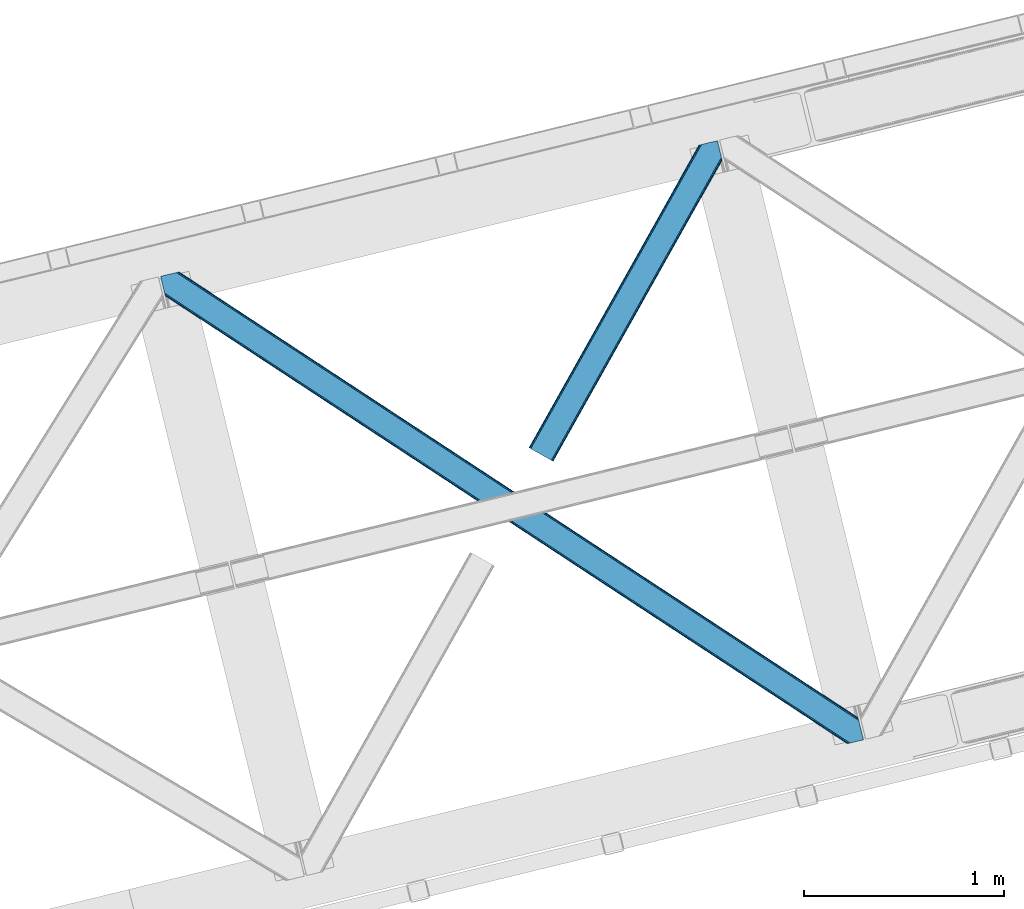
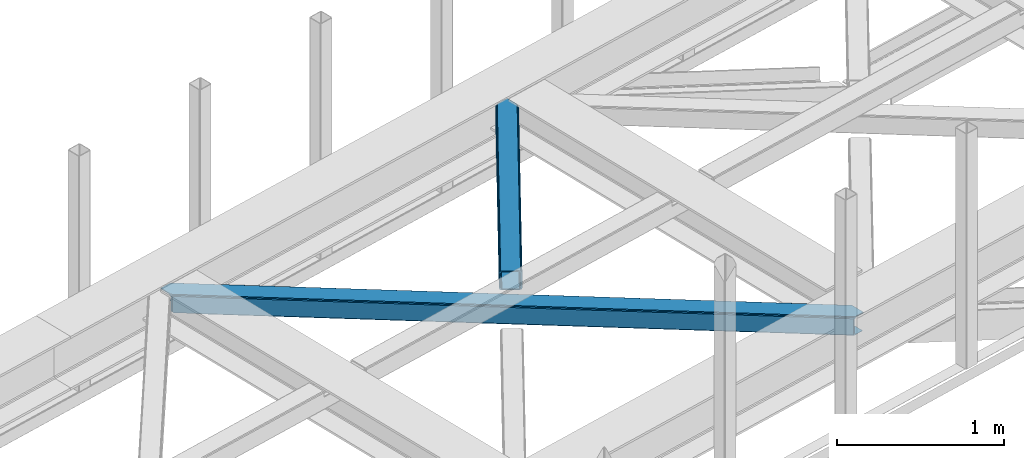
# One storey, part 54 of 67: 2 members.
"""IFC4 building model written with IfcOpenShell, lengths in millimetres."""

from ifc_helpers import new_model, entity, si_unit, converted_unit, derived_unit, direction, frame, origin, place, context, subcontext, project, spatial, triangles, type_object, element, save


model = new_model("IFC4")

# Units and contexts
model_context = context("Model", 3, precision=0.01, world=origin(), true_north=direction((6.12303176911189e-17, 1.0)))
plan_context = context("Plan", 3, precision=0.01, world=origin(), true_north=direction((6.12303176911189e-17, 1.0)))
body_context = subcontext(model_context, "Body", "Model", "MODEL_VIEW")
ifc_project = project(units=[si_unit("LENGTHUNIT", "METRE", prefix="MILLI"), si_unit("AREAUNIT", "SQUARE_METRE"), si_unit("VOLUMEUNIT", "CUBIC_METRE"), converted_unit("PLANEANGLEUNIT", "DEGREE", entity("IfcRatioMeasure", 0.0174532925199433), si_unit("PLANEANGLEUNIT", "RADIAN"), dimensions=[0, 0, 0, 0, 0, 0, 0]), si_unit("MASSUNIT", "GRAM", prefix="KILO"), derived_unit("MASSDENSITYUNIT", [(si_unit("MASSUNIT", "GRAM", prefix="KILO"), 1), (si_unit("LENGTHUNIT", "METRE"), -3)]), derived_unit("MOMENTOFINERTIAUNIT", [(si_unit("LENGTHUNIT", "METRE"), 4)]), si_unit("TIMEUNIT", "SECOND"), si_unit("FREQUENCYUNIT", "HERTZ"), si_unit("THERMODYNAMICTEMPERATUREUNIT", "DEGREE_CELSIUS"), derived_unit("THERMALTRANSMITTANCEUNIT", [(si_unit("MASSUNIT", "GRAM", prefix="KILO"), 1), (si_unit("THERMODYNAMICTEMPERATUREUNIT", "KELVIN"), -1), (si_unit("TIMEUNIT", "SECOND"), -3)]), derived_unit("VOLUMETRICFLOWRATEUNIT", [(si_unit("LENGTHUNIT", "METRE"), 3), (si_unit("TIMEUNIT", "SECOND"), -1)]), derived_unit("MASSFLOWRATEUNIT", [(si_unit("MASSUNIT", "GRAM", prefix="KILO"), 1), (si_unit("TIMEUNIT", "SECOND"), -1)]), derived_unit("ROTATIONALFREQUENCYUNIT", [(si_unit("TIMEUNIT", "SECOND"), -1)]), si_unit("ELECTRICCURRENTUNIT", "AMPERE"), si_unit("ELECTRICVOLTAGEUNIT", "VOLT"), si_unit("POWERUNIT", "WATT"), si_unit("FORCEUNIT", "NEWTON", prefix="KILO"), si_unit("ILLUMINANCEUNIT", "LUX"), si_unit("LUMINOUSFLUXUNIT", "LUMEN"), si_unit("LUMINOUSINTENSITYUNIT", "CANDELA"), derived_unit("USERDEFINED", [(si_unit("MASSUNIT", "GRAM", prefix="KILO"), -1), (si_unit("LENGTHUNIT", "METRE"), -2), (si_unit("TIMEUNIT", "SECOND"), 3), (si_unit("LUMINOUSFLUXUNIT", "LUMEN"), 1)]), derived_unit("LINEARVELOCITYUNIT", [(si_unit("LENGTHUNIT", "METRE"), 1), (si_unit("TIMEUNIT", "SECOND"), -1)]), si_unit("PRESSUREUNIT", "PASCAL"), derived_unit("USERDEFINED", [(si_unit("LENGTHUNIT", "METRE"), -2), (si_unit("MASSUNIT", "GRAM", prefix="KILO"), 1), (si_unit("TIMEUNIT", "SECOND"), -2)]), derived_unit("LINEARFORCEUNIT", [(si_unit("MASSUNIT", "GRAM", prefix="KILO"), 1), (si_unit("LENGTHUNIT", "METRE"), 1), (si_unit("TIMEUNIT", "SECOND"), -2), (si_unit("LENGTHUNIT", "METRE"), -1)]), derived_unit("PLANARFORCEUNIT", [(si_unit("MASSUNIT", "GRAM", prefix="KILO"), 1), (si_unit("LENGTHUNIT", "METRE"), 1), (si_unit("TIMEUNIT", "SECOND"), -2), (si_unit("LENGTHUNIT", "METRE"), -2)])], contexts=[model_context, plan_context])

# Site, building, storey
site_placement = place(None, origin())
site = spatial("IfcSite", under=ifc_project, at=site_placement, CompositionType="ELEMENT")
building_placement = place(site_placement, origin())
building = spatial("IfcBuilding", under=site, at=building_placement, CompositionType="ELEMENT")
storey_placement = place(building_placement, frame((0.0, 0.0, 19800.0)))
storey = spatial("IfcBuildingStorey", under=building, at=storey_placement, CompositionType="ELEMENT", Elevation=19800.0)

# Members
member_type_1 = type_object("IfcMemberType", PredefinedType="BRACE")
member_1_placement = place(storey_placement, frame((-11734.9697570801, 15585.6370422363, 3822.99993896484)))
element("IfcMember", 1, at=member_1_placement, inside=storey, type_object=member_type_1, ObjectType="Steel Horizontal Brace", PredefinedType="BRACE", context=body_context, shape_type="Tessellation", body=[
    triangles([(2937.7294052124, 494.760498046875, 17.5012573242202), (3489.95093078613, 132.252392578124, 122.499499511719), (3489.95093078613, 132.252392578124, 17.5012573242202), (2364.46672210693, 871.079388427734, 17.5012573242202), (1791.19996948242, 1247.39827880859, 17.5012573242202), (93.3036071777333, 2361.98373413086, 122.499499511719), (644.675765991211, 2000.03838500976, 17.5012573242202), (93.3036071777333, 2361.98373413086, 17.5012573242202), (1217.93728637695, 1623.71833190918, 17.5012573242202), (3496.02555999756, 107.331820678712, 140.00075683594), (3493.70128326416, 116.868447875977, 138.668280029298), (70.0515380859379, 2356.31547546387, 140.00075683594), (78.9486694335938, 2358.48394775391, 138.668280029298), (3491.73047332764, 124.954000854492, 134.87548828125), (86.4947204589844, 2360.32337036133, 134.87548828125), (3490.41311187744, 130.355996704102, 129.196765136719), (91.5327850341801, 2361.5523651123, 129.196765136719), (18.1488922119133, 2264.78617858887, 140.00075683594), (0.0, 2339.23977355957, 140.00075683594), (3459.55685577393, 5.66825866699219, 140.00075683594), (3517.37193145752, 19.761584472657, 140.00075683594), (3436.30420532227, 0.0, 122.499499511719), (3438.07560882568, 0.431369018555415, 129.196765136719), (24.2241027832024, 2239.86444396973, 122.499499511719), (23.7613403320302, 2241.76083984375, 129.196765136719), (3443.11367340088, 1.66036376953161, 134.87548828125), (22.4439788818363, 2247.16399841309, 134.87548828125), (3450.65972442627, 3.49978637695313, 138.668280029298), (20.4731689453129, 2255.24838867188, 138.668280029298), (1732.10008850098, 1118.72590026855, 17.5012573242202), (2308.23352661133, 740.523403930663, 17.5012573242202), (2884.36754608154, 362.320907592773, 17.5012573242202), (3436.30420532227, 0.0, 17.5012573242202), (1155.9701385498, 1496.92839660645, 17.5012573242202), (579.836700439453, 1875.13089294434, 17.5012573242202), (24.2241027832024, 2239.86444396973, 17.5012573242202), (21.3312561035145, 2251.7299987793, 122.197192382813), (20.0138946533207, 2257.13199462891, 127.873590087893), (21.7940185546868, 2249.83244018555, 115.499926757813), (21.7940185546868, 2249.83244018555, 24.5008300781265), (21.2382385253895, 2252.11137084961, 17.8686767578147), (21.1254547119133, 2252.57413330078, 16.5199218750022), (24.2136383056641, 2239.90397644043, 16.5199218750022), (18.0430847167972, 2265.21754760742, 131.668707275392), (15.7188079833977, 2274.75417480469, 133.001184082033), (0.0, 2339.23977355957, 133.001184082033), (3468.86035766602, 7.93556213378906, 133.001184082033), (3459.96322631836, 5.76708984375, 131.668707275392), (3452.41775665283, 3.92766723632849, 127.873590087893), (3447.37504119873, 2.69867248535229, 122.197192382813), (3445.60828857422, 2.26846618652417, 115.499926757813), (2899.81544036865, 360.552410888671, 24.5008300781265), (3445.60828857422, 2.26846618652417, 24.5008300781265), (2319.7380569458, 741.344284057617, 24.5008300781265), (1739.66009216309, 1122.13499450684, 24.5008300781265), (579.508813476563, 1883.71874084473, 24.5008300781265), (1159.58735961914, 1502.92803039551, 24.5008300781265), (60.7474548339833, 2354.04817199707, 133.001184082033), (3498.45564422607, 97.3626617431637, 133.001184082033), (3517.37193145752, 19.761584472657, 133.001184082033), (3492.38101501465, 122.284396362305, 115.499926757813), (3492.84319610596, 120.386837768554, 122.197192382813), (82.2333526611328, 2359.28506164551, 122.197192382813), (84.0041748046879, 2359.71759338379, 115.499926757813), (3494.15997619629, 114.984841918946, 127.873590087893), (77.1906372070316, 2358.05606689453, 127.873590087893), (3496.13078613281, 106.899288940429, 131.668707275392), (69.6492370605465, 2356.21780700684, 131.668707275392), (1789.35473327637, 1240.23941345215, 24.5008300781265), (2366.84622802734, 861.141622924806, 24.5008300781265), (2944.34237365723, 482.043832397461, 24.5008300781265), (3492.38101501465, 122.284396362305, 24.5008300781265), (1211.85858764648, 1619.33604125976, 24.5008300781265), (634.362442016602, 1998.43383178711, 24.5008300781265), (84.0041748046879, 2359.71759338379, 24.5008300781265), (82.2333526611328, 2359.28506164551, 17.8035644531265), (91.1804809570313, 2361.46632385254, 10.8691040039084), (90.7467864990231, 2361.36051635742, 9.52034912109593), (77.1906372070316, 2358.05606689453, 12.1248413085959), (72.7711395263668, 2356.97938842774, 9.52034912109593), (3494.1646270752, 114.986004638671, 127.873590087893), (3491.73919372559, 124.956326293945, 134.87548828125), (3493.71000366211, 116.87077331543, 138.668280029298), (3498.46029510498, 97.363824462891, 133.001184082033), (3496.13543701172, 106.900451660156, 131.668707275392), (3496.03486175537, 107.332983398437, 140.00075683594), (3517.35856018066, 19.7580963134769, 133.001184082033), (3517.36262969971, 19.7592590332024, 140.00075683594), (3490.13871002197, 131.207107543945, 12.5201660156272), (3492.77982788086, 120.37172241211, 17.8035644531265), (3494.03556518555, 115.201107788085, 12.2132080078118), (3489.89221343994, 132.238439941406, 17.5012573242202), (3489.95558166504, 132.253555297852, 122.499499511719), (3492.32229766846, 122.270443725585, 24.5008300781265), (3492.37636413574, 122.283233642578, 115.499926757813), (3490.42241363525, 130.358322143555, 129.196765136719), (30.6016204833977, 2237.5390045166, 10.8714294433594), (27.4366973876949, 2256.23902587891, 9.52034912109593), (25.3949615478505, 2253.59616394043, 12.1248413085959), (32.1329223632802, 2236.97508544922, 9.52034912109593), (161.614553833007, 2168.15486755371, 9.52034912109593), (143.640069580078, 2163.77373962402, 9.52034912109593), (580.237838745117, 1884.83262634277, 17.8035644531265), (582.322595214844, 1888.00452575683, 12.1248413085959), (585.436358642577, 1892.74958496094, 8.3320495605476), (589.112878417969, 1898.34808044434, 6.99957275390625), (173.638238525391, 2171.08608398437, 6.99957275390625), (164.935281372071, 2168.9641204834, 8.82504272460938), (3459.96322631836, 5.76708984375, 8.3320495605476), (3468.86035766602, 7.93556213378906, 6.99957275390625), (2909.4189239502, 375.181750488282, 6.99957275390625), (2905.7424041748, 369.583255004884, 8.3320495605476), (3452.41775665283, 3.92766723632849, 12.1248413085959), (2902.62922210693, 364.837033081054, 12.1248413085959), (3447.37504119873, 2.69867248535229, 17.8035644531265), (2900.54446563721, 361.665133666993, 17.8035644531265), (2320.47173309326, 742.458169555664, 17.8035644531265), (1740.39376831055, 1123.25004272461, 17.8035644531265), (1160.3163848877, 1504.04075317383, 17.8035644531265), (2322.55183868408, 745.62890625, 12.1248413085959), (1742.47387390137, 1126.42077941895, 12.1248413085959), (1162.39649047852, 1507.21148986816, 12.1248413085959), (2325.66502075195, 750.373965454102, 8.3320495605476), (1745.59228820801, 1131.16700134277, 8.3320495605476), (1165.51374206543, 1511.95887451172, 8.3320495605476), (2329.34095916748, 755.973623657226, 6.99957275390625), (1749.26299438477, 1136.76433410645, 6.99957275390625), (1169.19026184082, 1517.55736999512, 6.99957275390625), (3442.60789031982, 1.53711547851526, 5.52059326172093), (3438.07560882568, 0.431369018555415, 10.8039916992202), (3510.57176513672, 18.1035461425781, 5.52059326172093), (3512.00830535889, 18.4535247802742, 6.99957275390625), (3493.80534667969, 115.144134521484, 12.2132080078118), (3483.02053985596, 131.129205322266, 5.52059326172093), (3488.60333862305, 131.20245666504, 10.9621215820334), (3491.00144805908, 110.268850708007, 8.3320495605476), (3490.20207824707, 131.222222900391, 12.5201660156272), (3491.69094085693, 101.803088378907, 6.99957275390625), (1202.25568542481, 1604.70670166016, 6.99957275390625), (624.759539794921, 1983.8044921875, 6.99957275390625), (1779.74718017578, 1225.60891113281, 6.99957275390625), (198.048376464843, 2177.0357208252, 6.99957275390625), (172.834799194336, 2280.4712677002, 6.99957275390625), (2934.73947143555, 467.414492797852, 6.99957275390625), (2357.24332580566, 846.512283325195, 6.99957275390625), (628.434896850586, 1989.4029876709, 8.3320495605476), (170.517498779296, 2289.97650146484, 8.42274169921802), (2938.41540985107, 473.012988281251, 8.3320495605476), (2941.52859191894, 477.759210205078, 12.1248413085959), (3492.84319610596, 120.386837768554, 17.8035644531265), (631.54866027832, 1994.148046875, 12.1248413085959), (168.980383300781, 2293.67046203613, 9.44360961914208), (169.43733215332, 2292.66005859375, 9.13665161133031), (169.896606445313, 2291.64035339356, 8.82736816406396), (168.468786621093, 2294.15996704101, 9.52034912109593), (633.62876586914, 1997.31878356934, 17.8035644531265), (2943.61334838867, 480.931109619141, 17.8035644531265), (2360.91926422119, 852.110778808594, 8.3320495605476), (1783.42369995117, 1231.20740661621, 8.3320495605476), (1205.92755432129, 1610.30403442383, 8.3320495605476), (2364.03709716797, 856.857000732423, 12.1248413085959), (1786.54095153809, 1235.95479125977, 12.1248413085959), (1209.0448059082, 1615.05141906738, 12.1248413085959), (2366.11720275879, 860.027737426757, 17.8035644531265), (1788.62105712891, 1239.1255279541, 17.8035644531265), (1211.12491149902, 1618.22215576172, 17.8035644531265), (164.479495239257, 2312.62628173828, 9.02037963867406), (165.189916992187, 2311.83098144531, 8.52041015625218), (163.772561645508, 2313.4239074707, 9.52034912109593), (166.108465576172, 2308.06260681152, 5.12526855468968), (170.40471496582, 2290.44042663574, 0.0), (168.079275512695, 2299.97705383301, 1.33247680664135), (198.048376464843, 2177.0357208252, 0.0), (164.338806152344, 2168.81878051758, 0.0), (155.438186645508, 2166.64914550781, 1.33247680664135), (147.892135620117, 2164.80972290039, 5.12526855468968), (643.942089843749, 1998.92333679199, 10.8039916992202), (3361.49016723633, 210.375531005859, 5.21363525390552), (2937.00037994385, 493.646612548828, 10.8039916992202), (2934.91562347412, 490.474713134765, 5.12526855468968), (3354.02957611084, 208.557037353516, 1.33247680664135), (641.86198425293, 1995.75260009766, 5.12526855468968), (638.743569946289, 1991.00637817383, 1.33247680664135), (635.071701049805, 1985.40788269043, 0.0), (3345.12837524414, 206.387402343749, 0.0), (2931.80244140625, 485.729653930664, 1.33247680664135), (2928.12592163086, 480.131158447266, 0.0), (2363.73304595947, 869.965502929688, 10.8039916992202), (1790.47094421387, 1246.28555603027, 10.8039916992202), (1217.2082611084, 1622.60560913086, 10.8039916992202), (2361.65294036865, 866.794766235351, 5.12526855468968), (1788.39083862305, 1243.11481933594, 5.12526855468968), (1215.12350463867, 1619.4337097168, 5.12526855468968), (2358.53510742187, 862.048544311525, 1.33247680664135), (1785.27242431641, 1238.36743469238, 1.33247680664135), (1212.01090393066, 1614.68748779297, 1.33247680664135), (2354.86381988525, 856.450048828126, 0.0), (1781.59706726074, 1232.76893920899, 0.0), (1208.33438415527, 1609.08899230957, 0.0), (589.439602661132, 1889.76023254394, 0.0), (1165.57304077148, 1511.55889892578, 0.0), (1741.70299072266, 1133.35523986816, 0.0), (2893.97044830322, 376.950247192382, 0.0), (2317.83642883301, 755.152743530274, 0.0), (3315.15171661377, 199.079708862304, 0.0), (3343.77031860352, 81.6775726318356, 0.0), (580.565725708007, 1876.24477844238, 10.8039916992202), (582.650482177734, 1879.41667785645, 5.12526855468968), (2887.18132781982, 366.605529785156, 5.12526855468968), (2890.2945098877, 371.351751708984, 1.33247680664135), (3346.09459533691, 72.139782714843, 1.33247680664135), (3347.84448852539, 64.9611511230469, 4.52065429687718), (2885.0965713501, 363.433630371093, 10.8039916992202), (3348.63630065918, 63.8344757080085, 5.02062377929906), (3349.42346191406, 62.7066375732429, 5.52059326172093), (585.763082885742, 1884.16173706055, 1.33247680664135), (2314.16049041748, 749.553085327148, 1.33247680664135), (1738.03112182617, 1127.75674438477, 1.33247680664135), (1161.89768371582, 1505.95924072266, 1.33247680664135), (2311.04730834961, 744.808026123046, 5.12526855468968), (1734.91387023926, 1123.01052246094, 5.12526855468968), (1158.77926940918, 1501.21301879883, 5.12526855468968), (2308.96255187988, 741.636126708985, 10.8039916992202), (1732.83376464844, 1119.8397857666, 10.8039916992202), (1156.69916381836, 1498.04228210449, 10.8039916992202), (3349.42346191406, 62.7066375732429, 5.51129150390625), (3361.48958587646, 210.375531005859, 5.38339233398438), (3483.02053985596, 131.129205322266, 5.43687744140698), (3316.12316894531, 199.316903686524, 5.39734497070458), (3442.60789031982, 1.53711547851526, 5.55314941406323), (3510.57176513672, 18.1035461425781, 5.53222045898656), (3316.12316894531, 199.316903686524, 5.52059326172093), (3315.15171661377, 199.079708862304, 4.52065429687718)], [[1, 2, 3], [2, 1, 4], [2, 5, 6], [5, 2, 4], [7, 8, 6], [9, 6, 5], [6, 9, 7], [10, 11, 12], [13, 12, 11], [11, 14, 13], [15, 13, 14], [14, 16, 15], [17, 15, 16], [16, 2, 17], [6, 17, 2], [12, 18, 10], [12, 19, 18], [20, 10, 18], [21, 10, 20], [22, 23, 24], [25, 24, 23], [23, 26, 25], [27, 25, 26], [26, 28, 27], [29, 27, 28], [28, 20, 29], [18, 29, 20], [30, 22, 24], [22, 31, 32], [30, 31, 22], [32, 33, 22], [34, 24, 35], [24, 34, 30], [36, 35, 24], [37, 27, 38], [39, 40, 24], [25, 37, 24], [37, 25, 27], [37, 39, 24], [40, 36, 24], [41, 42, 43], [43, 36, 41], [40, 41, 36], [44, 29, 18], [19, 45, 18], [46, 45, 19], [44, 38, 29], [29, 38, 27], [45, 44, 18], [47, 48, 44], [44, 45, 47], [48, 49, 38], [38, 44, 48], [49, 50, 37], [37, 38, 49], [50, 51, 39], [39, 37, 50], [52, 51, 53], [51, 52, 54], [51, 55, 39], [55, 51, 54], [56, 40, 39], [57, 39, 55], [39, 57, 56], [45, 58, 59], [58, 45, 46], [59, 47, 45], [60, 47, 59], [61, 62, 63], [63, 64, 61], [62, 65, 66], [66, 63, 62], [65, 67, 68], [68, 66, 65], [67, 59, 58], [58, 68, 67], [69, 61, 64], [61, 70, 71], [69, 70, 61], [71, 72, 61], [73, 64, 74], [64, 73, 69], [75, 74, 64], [66, 68, 13], [15, 66, 13], [15, 17, 63], [66, 15, 63], [63, 17, 6], [68, 12, 13], [19, 58, 46], [19, 12, 58], [68, 58, 12], [63, 6, 64], [75, 8, 76], [6, 75, 64], [8, 77, 76], [6, 8, 75], [78, 76, 77], [79, 76, 78], [80, 79, 78], [81, 82, 83], [82, 81, 62], [84, 85, 86], [85, 81, 83], [87, 84, 88], [86, 88, 84], [85, 83, 86], [89, 90, 91], [92, 93, 94], [94, 90, 92], [89, 92, 90], [93, 95, 94], [62, 96, 82], [93, 96, 62], [95, 93, 62], [97, 98, 99], [97, 100, 98], [99, 43, 97], [42, 43, 99], [100, 98, 101], [101, 102, 100], [103, 104, 99], [99, 42, 103], [103, 41, 40], [105, 106, 107], [104, 105, 108], [108, 101, 104], [104, 101, 99], [98, 99, 101], [107, 108, 105], [109, 110, 111], [111, 112, 109], [113, 109, 112], [112, 114, 113], [115, 113, 114], [114, 116, 115], [53, 115, 116], [116, 52, 53], [40, 56, 103], [42, 41, 103], [52, 116, 54], [117, 54, 116], [54, 117, 118], [118, 55, 54], [55, 118, 119], [119, 57, 55], [57, 119, 103], [103, 56, 57], [116, 114, 120], [120, 117, 116], [117, 120, 121], [121, 118, 117], [118, 121, 119], [122, 119, 121], [119, 122, 103], [104, 103, 122], [114, 112, 120], [123, 120, 112], [120, 123, 124], [124, 121, 120], [121, 124, 125], [125, 122, 121], [122, 125, 105], [105, 104, 122], [112, 111, 126], [126, 123, 112], [123, 126, 127], [127, 124, 123], [124, 127, 125], [128, 125, 127], [125, 128, 106], [106, 105, 125], [49, 48, 28], [26, 49, 28], [50, 26, 23], [50, 22, 51], [26, 50, 49], [22, 50, 23], [48, 20, 28], [21, 47, 60], [21, 20, 47], [48, 47, 20], [22, 53, 51], [129, 113, 115], [115, 53, 33], [33, 53, 22], [115, 130, 129], [130, 115, 33], [131, 110, 129], [110, 109, 129], [109, 113, 129], [131, 132, 110], [133, 134, 135], [136, 134, 133], [135, 137, 133], [132, 131, 138], [138, 134, 136], [134, 138, 131], [139, 140, 106], [106, 128, 139], [128, 141, 139], [141, 128, 127], [106, 142, 107], [142, 140, 143], [106, 140, 142], [138, 144, 111], [111, 110, 138], [132, 138, 110], [144, 126, 111], [145, 127, 126], [127, 145, 141], [144, 145, 126], [146, 147, 143], [148, 136, 133], [149, 133, 150], [151, 152, 153], [153, 146, 151], [153, 154, 146], [154, 147, 146], [155, 151, 79], [79, 80, 155], [151, 156, 76], [76, 79, 151], [156, 74, 75], [75, 76, 156], [150, 72, 157], [71, 157, 72], [150, 157, 149], [133, 149, 148], [138, 136, 144], [148, 144, 136], [143, 140, 146], [144, 148, 145], [158, 145, 148], [145, 158, 141], [159, 141, 158], [141, 159, 160], [160, 139, 141], [139, 160, 146], [146, 140, 139], [148, 149, 161], [161, 158, 148], [158, 161, 159], [162, 159, 161], [159, 162, 160], [163, 160, 162], [160, 163, 146], [151, 146, 163], [149, 157, 164], [164, 161, 149], [161, 164, 165], [165, 162, 161], [162, 165, 163], [166, 163, 165], [163, 166, 151], [156, 151, 166], [157, 71, 70], [70, 164, 157], [164, 70, 69], [69, 165, 164], [165, 69, 73], [73, 166, 165], [166, 73, 74], [74, 156, 166], [167, 153, 152], [168, 154, 153], [168, 147, 154], [80, 78, 169], [169, 155, 80], [147, 168, 170], [171, 147, 172], [170, 172, 147], [147, 171, 143], [143, 173, 142], [173, 143, 171], [108, 107, 174], [101, 174, 175], [175, 176, 101], [173, 107, 142], [107, 173, 174], [176, 102, 101], [174, 101, 108], [177, 77, 8], [1, 137, 135], [1, 3, 137], [135, 134, 178], [178, 179, 135], [180, 178, 181], [77, 177, 169], [177, 182, 170], [170, 168, 177], [177, 168, 167], [167, 169, 177], [169, 78, 77], [182, 183, 172], [172, 170, 182], [183, 184, 171], [171, 172, 183], [181, 185, 186], [187, 186, 185], [181, 186, 180], [178, 180, 179], [135, 179, 1], [8, 7, 177], [1, 179, 4], [188, 4, 179], [4, 188, 5], [189, 5, 188], [5, 189, 190], [190, 9, 5], [9, 190, 177], [177, 7, 9], [179, 180, 188], [191, 188, 180], [188, 191, 189], [192, 189, 191], [189, 192, 190], [193, 190, 192], [190, 193, 177], [182, 177, 193], [180, 186, 194], [194, 191, 180], [191, 194, 195], [195, 192, 191], [192, 195, 193], [196, 193, 195], [193, 196, 182], [183, 182, 196], [186, 187, 197], [197, 194, 186], [194, 197, 198], [198, 195, 194], [195, 198, 199], [199, 196, 195], [196, 199, 184], [184, 183, 196], [200, 174, 173], [184, 200, 173], [184, 173, 171], [199, 200, 184], [201, 200, 199], [198, 201, 199], [201, 198, 202], [187, 203, 204], [202, 197, 204], [197, 202, 198], [197, 187, 204], [187, 205, 203], [203, 205, 206], [185, 205, 187], [35, 36, 97], [36, 43, 97], [207, 97, 102], [102, 208, 207], [102, 176, 208], [97, 100, 102], [209, 210, 211], [211, 212, 209], [213, 209, 214], [130, 33, 213], [32, 213, 33], [129, 130, 215], [213, 215, 130], [212, 214, 209], [206, 211, 210], [210, 203, 206], [200, 216, 174], [175, 174, 216], [216, 208, 175], [176, 175, 208], [97, 207, 35], [203, 210, 204], [217, 204, 210], [204, 217, 202], [218, 202, 217], [202, 218, 219], [219, 201, 202], [201, 219, 200], [216, 200, 219], [210, 209, 217], [220, 217, 209], [217, 220, 218], [221, 218, 220], [218, 221, 219], [222, 219, 221], [219, 222, 208], [208, 216, 219], [209, 213, 223], [223, 220, 209], [220, 223, 221], [224, 221, 223], [221, 224, 222], [225, 222, 224], [222, 225, 208], [207, 208, 225], [213, 32, 31], [31, 223, 213], [223, 31, 224], [30, 224, 31], [224, 30, 34], [34, 225, 224], [225, 34, 35], [35, 207, 225], [226, 227, 228], [227, 226, 229], [228, 230, 226], [231, 230, 228], [185, 232, 205], [178, 185, 181], [205, 232, 233], [178, 232, 185], [206, 233, 212], [206, 205, 233], [212, 211, 206]]),
])
member_type_2 = type_object("IfcMemberType", PredefinedType="BRACE")
member_2_placement = place(storey_placement, frame((-9892.01829528809, 16998.9926330566, 3822.99993896484)))
element("IfcMember", 2, at=member_2_placement, inside=storey, type_object=member_type_2, ObjectType="Steel Horizontal Brace", PredefinedType="BRACE", context=body_context, shape_type="Tessellation", body=[
    triangles([(963.930697631835, 1521.10947875976, 138.668280029298), (961.605839538573, 1530.64726867676, 140.00075683594), (106.810922241211, 8.56924438476563, 140.00075683594), (112.650100708008, 5.29037475585938, 138.668280029298), (965.901507568358, 1513.02508850098, 134.87548828125), (117.598635864257, 2.50914916992042, 134.87548828125), (967.21828765869, 1507.62192993164, 129.196765136719), (120.908898925782, 0.65228576660229, 129.196765136719), (967.680468749999, 1505.72553405762, 122.499499511719), (122.068130493164, 0.0, 122.499499511719), (967.680468749999, 1505.72553405762, 17.5012573242202), (122.068130493164, 0.0, 17.5012573242202), (15.2572082519528, 59.9835479736321, 140.00075683594), (873.405409240722, 1588.02516174316, 140.00075683594), (943.45694732666, 1605.10086364746, 140.00075683594), (851.919511413575, 1582.78827209473, 129.196765136719), (850.152758789061, 1582.35690307617, 122.499499511719), (1.16388244628797, 67.9005065917954, 129.196765136719), (0.0, 68.5527923583977, 122.499499511719), (856.962226867676, 1584.0172668457, 134.87548828125), (4.46949462890552, 66.04248046875, 134.87548828125), (864.503627014159, 1585.8555267334, 138.668280029298), (9.4215179443363, 63.2635803222656, 138.668280029298), (850.152758789061, 1582.35690307617, 17.5012573242202), (0.0, 68.5527923583977, 17.5012573242202), (1.16388244628797, 67.9005065917954, 10.8039916992202), (809.934864807128, 1506.81616516113, 9.52034912109593), (809.674415588379, 1505.78367004394, 9.02037963867406), (4.46949462890552, 66.04248046875, 5.12526855468968), (809.409315490722, 1504.7488494873, 8.52041015625218), (810.327864074707, 1500.98047485352, 5.12526855468968), (852.276466369629, 1582.87431335449, 10.8691040039084), (852.710160827637, 1582.98012084961, 9.52034912109593), (812.29867401123, 1492.89608459473, 1.33247680664135), (814.623532104491, 1483.35829467774, 0.0), (9.4215179443363, 63.2635803222656, 1.33247680664135), (15.2572082519528, 59.9835479736321, 0.0), (842.022441101073, 1370.95817871094, 0.0), (106.810922241211, 8.56924438476563, 0.0), (876.670907592774, 1379.40417480469, 0.0), (814.517724609375, 1484.6570526123, 8.82736816406396), (814.736315917968, 1482.89553222656, 8.42274169921802), (814.460751342773, 1485.77442626953, 9.13665161133031), (814.401452636719, 1486.88249816895, 9.44360961914208), (814.630508422852, 1487.55222473144, 9.52034912109593), (870.68522644043, 1587.36241149902, 9.52034912109593), (817.053616333007, 1473.39029846191, 6.99957275390625), (842.022441101073, 1370.95817871094, 6.99957275390625), (15.5234710693348, 59.8347198486335, 8.3320495605476), (21.3638122558586, 56.5558502197273, 6.99957275390625), (866.261659240723, 1586.28340759277, 12.1248413085959), (10.5714477539059, 62.6147827148452, 12.1248413085959), (861.223013305664, 1585.05557556152, 17.8035644531265), (859.452191162109, 1584.62420654297, 24.5008300781265), (7.26467285156286, 64.4728088378906, 17.8035644531265), (6.1054412841786, 65.1250946044929, 24.5008300781265), (100.704318237304, 11.9957794189468, 6.99957275390625), (867.366824340819, 1377.13687133789, 6.99957275390625), (885.567457580566, 1381.57380981445, 1.33247680664135), (879.391090393066, 1380.06808776856, 9.52034912109593), (893.113508605957, 1383.41323242187, 5.12526855468968), (876.06978149414, 1379.25767211914, 8.82504272460938), (897.365574645995, 1384.44921569824, 9.52034912109593), (963.083074951172, 1500.72467651367, 10.8714294433594), (120.908898925782, 0.65228576660229, 10.8039916992202), (117.598635864257, 2.50914916992042, 5.12526855468968), (967.671166992188, 1505.76390380859, 16.5199218750022), (961.988374328614, 1499.52126159668, 9.52034912109593), (112.650100708008, 5.29037475585938, 1.33247680664135), (960.31696472168, 1517.3771484375, 12.1248413085959), (964.582402038573, 1518.43522338867, 16.5199218750022), (957.29273071289, 1518.78520202637, 9.52034912109593), (114.803457641601, 4.07998352050708, 17.8035644531265), (115.967340087891, 3.42769775390479, 24.5008300781265), (965.250965881347, 1515.69353027344, 24.5008300781265), (964.69518585205, 1517.9724609375, 17.8686767578147), (111.496682739258, 5.93800964355614, 12.1248413085959), (106.544659423827, 8.71690979004052, 8.3320495605476), (965.250965881347, 1515.69353027344, 115.499926757813), (115.967340087891, 3.42769775390479, 115.499926757813), (964.788203430175, 1517.59108886719, 122.197192382813), (963.471423339843, 1522.9930847168, 127.873590087893), (961.500613403319, 1531.07863769531, 131.668707275392), (959.175755310058, 1540.61526489258, 133.001184082033), (943.45694732666, 1605.10086364746, 133.001184082033), (114.803457641601, 4.07998352050708, 122.197192382813), (111.496682739258, 5.93800964355614, 127.873590087893), (106.544659423827, 8.71690979004052, 131.668707275392), (100.704318237304, 11.9957794189468, 133.001184082033), (10.5714477539059, 62.6147827148452, 127.873590087893), (21.3638122558586, 56.5558502197273, 133.001184082033), (15.5234710693348, 59.8347198486335, 131.668707275392), (6.1054412841786, 65.1250946044929, 115.499926757813), (7.26467285156286, 64.4728088378906, 122.197192382813), (861.223013305664, 1585.05557556152, 122.197192382813), (873.807710266114, 1588.12283020019, 131.668707275392), (882.70484161377, 1590.29246520996, 133.001184082033), (866.261659240723, 1586.28340759277, 127.873590087893), (859.452191162109, 1584.62420654297, 115.499926757813)], [[1, 2, 3], [3, 4, 1], [5, 1, 4], [4, 6, 5], [7, 5, 6], [6, 8, 7], [9, 7, 8], [8, 10, 9], [11, 9, 10], [10, 12, 11], [13, 2, 14], [13, 3, 2], [2, 15, 14], [16, 17, 18], [19, 18, 17], [20, 16, 21], [18, 21, 16], [22, 20, 23], [21, 23, 20], [14, 22, 13], [23, 13, 22], [17, 24, 19], [25, 19, 24], [26, 25, 24], [27, 28, 29], [30, 29, 28], [30, 31, 29], [26, 32, 27], [27, 29, 26], [32, 33, 27], [34, 35, 36], [37, 36, 35], [31, 34, 29], [36, 29, 34], [24, 32, 26], [38, 37, 35], [39, 38, 40], [38, 39, 37], [41, 42, 30], [43, 41, 30], [44, 43, 28], [45, 27, 46], [33, 46, 27], [34, 42, 35], [30, 42, 31], [31, 42, 34], [47, 35, 42], [47, 38, 35], [38, 47, 48], [49, 50, 47], [44, 51, 52], [44, 46, 51], [52, 49, 42], [43, 52, 41], [43, 44, 52], [52, 42, 41], [47, 42, 49], [53, 54, 55], [56, 55, 54], [51, 53, 52], [55, 52, 53], [48, 57, 58], [50, 48, 47], [48, 50, 57], [59, 60, 61], [58, 38, 48], [58, 62, 40], [58, 40, 38], [40, 60, 59], [61, 60, 63], [62, 60, 40], [64, 65, 63], [65, 66, 61], [61, 63, 65], [12, 65, 64], [64, 11, 12], [64, 67, 11], [63, 68, 64], [59, 61, 66], [66, 69, 59], [40, 59, 69], [69, 39, 40], [70, 67, 64], [70, 71, 67], [64, 72, 70], [68, 72, 64], [63, 60, 68], [72, 68, 60], [73, 74, 75], [73, 71, 70], [73, 76, 71], [77, 70, 60], [60, 78, 77], [60, 62, 78], [70, 72, 60], [78, 62, 58], [58, 57, 78], [70, 77, 73], [75, 76, 73], [79, 75, 74], [74, 80, 79], [76, 67, 71], [9, 11, 75], [11, 76, 75], [75, 79, 9], [11, 67, 76], [81, 9, 79], [7, 9, 81], [5, 81, 82], [81, 5, 7], [82, 1, 5], [83, 1, 82], [83, 84, 2], [83, 2, 1], [84, 15, 2], [84, 85, 15], [81, 79, 86], [80, 86, 79], [82, 81, 87], [86, 87, 81], [83, 82, 88], [87, 88, 82], [84, 83, 89], [88, 89, 83], [8, 87, 86], [80, 12, 10], [8, 86, 10], [8, 6, 87], [86, 80, 10], [87, 6, 4], [89, 3, 13], [3, 88, 4], [88, 3, 89], [88, 87, 4], [65, 77, 66], [74, 12, 80], [12, 73, 65], [73, 12, 74], [65, 73, 77], [39, 57, 37], [69, 66, 77], [77, 78, 69], [78, 57, 39], [39, 69, 78], [90, 23, 21], [13, 91, 89], [13, 92, 91], [92, 13, 23], [90, 92, 23], [93, 19, 25], [18, 94, 90], [21, 18, 90], [94, 18, 19], [93, 94, 19], [36, 52, 29], [37, 57, 50], [50, 49, 37], [49, 52, 36], [36, 37, 49], [26, 29, 52], [25, 56, 93], [55, 25, 26], [25, 55, 56], [55, 26, 52], [95, 17, 16], [96, 22, 14], [15, 97, 14], [97, 15, 85], [97, 96, 14], [98, 22, 96], [98, 95, 20], [20, 22, 98], [16, 20, 95], [54, 24, 17], [51, 33, 53], [95, 99, 17], [51, 46, 33], [54, 53, 24], [99, 54, 17], [32, 24, 53], [53, 33, 32], [91, 84, 89], [84, 91, 97], [85, 84, 97], [54, 99, 93], [93, 56, 54], [96, 97, 91], [91, 92, 96], [98, 96, 92], [92, 90, 98], [95, 98, 90], [90, 94, 95], [99, 95, 94], [94, 93, 99]]),
])

save(model, "model.ifc")
